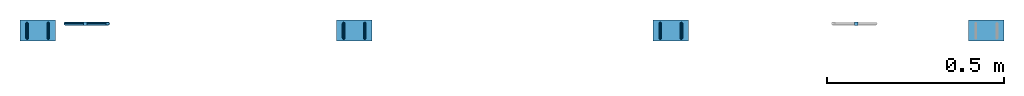
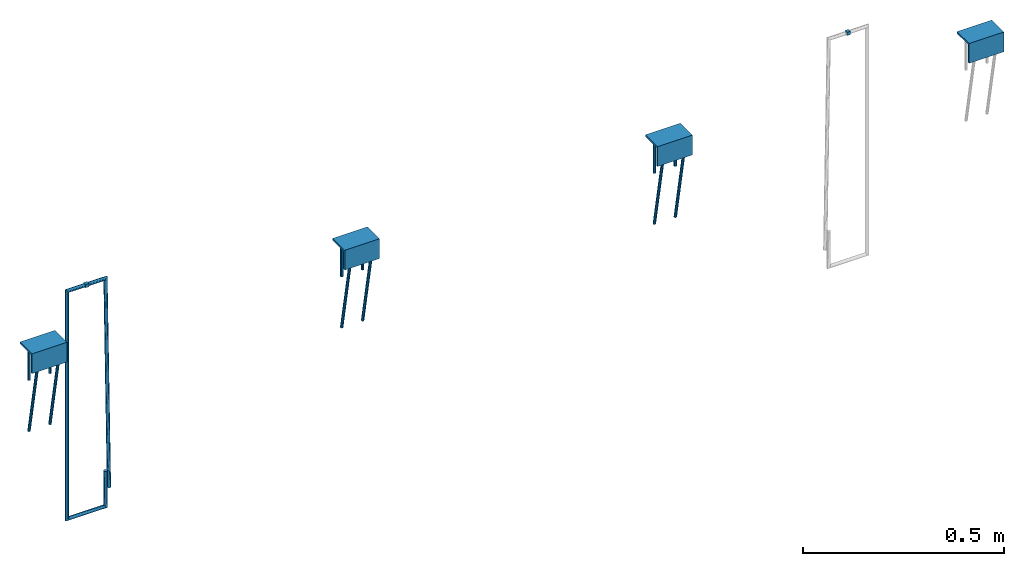
# One storey, part 1 of 2: 7 reinforcing bars, 4 plates, 2 beams, 6 elements without a shape of their own.
"""IFC2X3 building model written with IfcOpenShell, lengths in millimetres."""

from ifc_helpers import new_model, entity, si_unit, frame, origin_with_axes, origin_2d_with_axis, place, context, subcontext, project, spatial, polyline, rectangle, outline, extrude, source, transform, mapped, material, type_object, element, aggregate, save


model = new_model("IFC2X3")

# Units and contexts
model_context = context("Model", 3, precision=1e-05, world=origin_with_axes())
body_context = subcontext(model_context, "Body", "Model", "MODEL_VIEW")
ifc_project = project(units=[si_unit("LENGTHUNIT", "METRE", prefix="MILLI"), si_unit("AREAUNIT", "SQUARE_METRE"), si_unit("VOLUMEUNIT", "CUBIC_METRE"), si_unit("MASSUNIT", "GRAM", prefix="KILO"), si_unit("TIMEUNIT", "SECOND"), si_unit("PLANEANGLEUNIT", "RADIAN"), si_unit("SOLIDANGLEUNIT", "STERADIAN"), si_unit("THERMODYNAMICTEMPERATUREUNIT", "DEGREE_CELSIUS"), si_unit("LUMINOUSINTENSITYUNIT", "LUMEN")], contexts=[model_context])

# Site, building, storey
site_placement = place(None, origin_with_axes())
site = spatial("IfcSite", under=ifc_project, at=site_placement, CompositionType="ELEMENT")
building_placement = place(site_placement, origin_with_axes())
building = spatial("IfcBuilding", under=site, at=building_placement, Name="Undefined", CompositionType="ELEMENT")
storey_placement = place(building_placement, origin_with_axes())
storey = spatial("IfcBuildingStorey", under=building, at=storey_placement, Name="Undefined", CompositionType="ELEMENT", Elevation=0.0)

# Assembly, beam
assembly_1_placement = place(storey_placement, origin_with_axes())
assembly_1 = element("IfcElementAssembly", 1, at=assembly_1_placement, inside=storey, Name="Steel Assembly", AssemblyPlace="NOTDEFINED", PredefinedType="RIGID_FRAME")
ifc_material_1 = material(Name="STEEL/Steel_Undefined")
beam_type = type_object("IfcBeamType", Name="10X10", PredefinedType="NOTDEFINED")
beam_1_placement = place(assembly_1_placement, frame((38911.3076741018, 12049.7402865055, 1630.62234437501), z_axis=(0.0, 0.0, 1.0), x_axis=(1.0, 0.0, 0.0)))
beam_1 = element("IfcBeam", 2, at=beam_1_placement, type_object=beam_type, material=ifc_material_1, Name="10", ObjectType="10X10", context=body_context, shape_type="SweptSolid", body=[
    extrude(rectangle(XDim=10.0, YDim=10.0, at=origin_2d_with_axis()), frame((10.0, 0.0, 0.0), z_axis=(-0.999999999999873, 5.04999964807549e-07, 0.0), x_axis=(-2.17238216866451e-12, -1.0, -1.93119301693619e-12)), (0.0, 0.0, 1.0), 10.0),
])
aggregate(assembly_1, [beam_1])

assembly_2_placement = place(storey_placement, origin_with_axes())
assembly_2 = element("IfcElementAssembly", 3, at=assembly_2_placement, inside=storey, Name="Steel Assembly", AssemblyPlace="NOTDEFINED", PredefinedType="RIGID_FRAME")
beam_2_placement = place(assembly_2_placement, frame((36739.0479725297, 12049.7402865055, 1630.64995363408), z_axis=(0.0, 0.0, 1.0), x_axis=(-0.999999999999873, 5.04999964807549e-07, 0.0)))
beam_2 = element("IfcBeam", 4, at=beam_2_placement, type_object=beam_type, material=ifc_material_1, Name="10", ObjectType="10X10", context=body_context, shape_type="SweptSolid", body=[
    extrude(rectangle(XDim=10.0, YDim=10.0, at=origin_2d_with_axis()), frame((10.0, 0.0, 0.0), z_axis=(-0.999999999999873, 5.04999964807549e-07, 0.0), x_axis=(-2.17238216866451e-12, -1.0, -1.93119301693619e-12)), (0.0, 0.0, 1.0), 10.0),
])

# Assembly, plate
assembly_3_placement = place(storey_placement, origin_with_axes())
assembly_3 = element("IfcElementAssembly", 5, at=assembly_3_placement, inside=storey, Name="Steel Assembly", AssemblyPlace="NOTDEFINED", PredefinedType="RIGID_FRAME")
plate_type = type_object("IfcPlateType", Name="PL100X60", PredefinedType="NOTDEFINED")
plate_1_placement = place(assembly_3_placement, frame((39284.9367436631, 11999.9982796697, 1515.55037109356), z_axis=(-0.999999999999873, 5.04999964807549e-07, 0.0), x_axis=(0.0, 1.0, 0.0)))
plate_1 = element("IfcPlate", 6, at=plate_1_placement, type_object=plate_type, material=ifc_material_1, ObjectType="PL100X60", context=body_context, shape_type="SweptSolid", body=[
    extrude(outline(polyline([(0.0, 0.0), (60.0000000000491, 0.0), (60.0000000000491, 6.0), (6.00000000000546, 6.0), (6.00000000000546, 60.0), (2.5465851649642e-11, 60.0), (0.0, 0.0)])), frame((1.81898940354586e-12, -4.54747350886464e-13, -50.0), z_axis=(0.0, 0.0, 1.0), x_axis=(1.0, 0.0, 0.0)), (0.0, 0.0, 1.0), 100.0),
])
aggregate(assembly_3, [plate_1])

assembly_4_placement = place(storey_placement, origin_with_axes())
assembly_4 = element("IfcElementAssembly", 7, at=assembly_4_placement, inside=storey, Name="Steel Assembly", AssemblyPlace="NOTDEFINED", PredefinedType="RIGID_FRAME")
plate_2_placement = place(assembly_4_placement, frame((38391.9567435577, 11999.9987281135, 1515.55037109323), z_axis=(-0.999999999999873, 5.04999964807549e-07, 0.0), x_axis=(0.0, 1.0, 0.0)))
plate_2 = element("IfcPlate", 8, at=plate_2_placement, type_object=plate_type, material=ifc_material_1, ObjectType="PL100X60", context=body_context, shape_type="SweptSolid", body=[
    extrude(outline(polyline([(0.0, 0.0), (60.0000000000491, 0.0), (60.0000000000491, 6.0), (6.00000000000546, 6.0), (6.00000000000546, 60.0), (2.5465851649642e-11, 60.0), (0.0, 0.0)])), frame((1.81898940354586e-12, -4.54747350886464e-13, -50.0), z_axis=(0.0, 0.0, 1.0), x_axis=(1.0, 0.0, 0.0)), (0.0, 0.0, 1.0), 100.0),
])

assembly_5_placement = place(storey_placement, origin_with_axes())
assembly_5 = element("IfcElementAssembly", 9, at=assembly_5_placement, inside=storey, Name="Steel Assembly", AssemblyPlace="NOTDEFINED", PredefinedType="RIGID_FRAME")
plate_3_placement = place(assembly_5_placement, frame((37495.9767435481, 11999.999180887, 1515.55037109289), z_axis=(-0.999999999999873, 5.04999964807549e-07, 0.0), x_axis=(0.0, 1.0, 0.0)))
plate_3 = element("IfcPlate", 10, at=plate_3_placement, type_object=plate_type, material=ifc_material_1, ObjectType="PL100X60", context=body_context, shape_type="SweptSolid", body=[
    extrude(outline(polyline([(0.0, 0.0), (60.0000000000491, 0.0), (60.0000000000491, 6.0), (6.00000000000546, 6.0), (6.00000000000546, 60.0), (2.5465851649642e-11, 60.0), (0.0, 0.0)])), frame((1.81898940354586e-12, -4.54747350886464e-13, -50.0), z_axis=(0.0, 0.0, 1.0), x_axis=(1.0, 0.0, 0.0)), (0.0, 0.0, 1.0), 100.0),
])

assembly_6_placement = place(storey_placement, origin_with_axes())
assembly_6 = element("IfcElementAssembly", 11, at=assembly_6_placement, inside=storey, Name="Steel Assembly", AssemblyPlace="NOTDEFINED", PredefinedType="RIGID_FRAME")
plate_4_placement = place(assembly_6_placement, frame((36599.996743559, 11999.9996336118, 1515.55037109256), z_axis=(-0.999999999999873, 5.04999964807549e-07, 0.0), x_axis=(0.0, 1.0, 0.0)))
plate_4 = element("IfcPlate", 12, at=plate_4_placement, type_object=plate_type, material=ifc_material_1, ObjectType="PL100X60", context=body_context, shape_type="SweptSolid", body=[
    extrude(outline(polyline([(0.0, 0.0), (60.0000000000491, 0.0), (60.0000000000491, 6.0), (6.00000000000546, 6.0), (6.00000000000546, 60.0), (2.5465851649642e-11, 60.0), (0.0, 0.0)])), frame((1.81898940354586e-12, -4.54747350886464e-13, -50.0), z_axis=(0.0, 0.0, 1.0), x_axis=(1.0, 0.0, 0.0)), (0.0, 0.0, 1.0), 100.0),
])

# Reinforcing bar
ifc_material_2 = material(Name="Undefined")
ifc_direction_1 = entity("IfcDirection", [-0.98195706540053, 1.76798970064306e-12, 0.189103997075631])
ifc_direction_2 = entity("IfcDirection", [-2.17238216866451e-12, -1.0, -1.93119301693619e-12])
ifc_direction_3 = entity("IfcDirection", [-0.18910399414149, 2.3071547736201e-12, -0.981957065965582])
shared_shape_1 = source(origin_with_axes(), body_context, "Body", "AdvancedSweptSolid", [
    entity("IfcSweptDiskSolid", entity("IfcCompositeCurve", [entity("IfcCompositeCurveSegment", "CONTINUOUS", True, entity("IfcTrimmedCurve", entity("IfcLine", entity("IfcCartesianPoint", [0.0, 0.0, 0.0]), entity("IfcVector", ifc_direction_1, 1.0)), [entity("IfcParameterValue", 0.0)], [entity("IfcParameterValue", 90.9999999521698)], True, "PARAMETER")), entity("IfcCompositeCurveSegment", "CONTINUOUS", True, entity("IfcTrimmedCurve", entity("IfcCircle", entity("IfcAxis2Placement3D", entity("IfcCartesianPoint", [-92.3837568576909, 1.97801539136402e-10, 1.49715067842899]), ifc_direction_2, entity("IfcDirection", [0.189103997075631, -2.30715477890295e-12, 0.98195706540053])), 16.0), [entity("IfcParameterValue", 0.0)], [entity("IfcParameterValue", 1.57079632978295)], True, "PARAMETER")), entity("IfcCompositeCurveSegment", "CONTINUOUS", True, entity("IfcTrimmedCurve", entity("IfcLine", entity("IfcCartesianPoint", [-108.09506991314, 2.26089374456993e-10, 4.52281458469285]), entity("IfcVector", ifc_direction_3, 1.0)), [entity("IfcParameterValue", 0.0)], [entity("IfcParameterValue", 8.99744408063349)], True, "PARAMETER")), entity("IfcCompositeCurveSegment", "CONTINUOUS", True, entity("IfcTrimmedCurve", entity("IfcCircle", entity("IfcAxis2Placement3D", entity("IfcCartesianPoint", [-94.0852094704034, 2.18367057009855e-10, -7.33795311217925]), ifc_direction_2, ifc_direction_1), 16.0), [entity("IfcParameterValue", 0.0)], [entity("IfcParameterValue", 1.57079632834512)], True, "PARAMETER")), entity("IfcCompositeCurveSegment", "CONTINUOUS", True, entity("IfcTrimmedCurve", entity("IfcLine", entity("IfcCartesianPoint", [-97.1108733523112, 2.55281533343625e-10, -23.049266172319]), entity("IfcVector", entity("IfcDirection", [0.981957066258735, -1.78005084783605e-12, -0.189103992619242]), 1.0)), [entity("IfcParameterValue", 0.0)], [entity("IfcParameterValue", 31.5166760442662)], True, "PARAMETER")), entity("IfcCompositeCurveSegment", "CONTINUOUS", True, entity("IfcTrimmedCurve", entity("IfcCircle", entity("IfcAxis2Placement3D", entity("IfcCartesianPoint", [-63.1371867237488, 1.64690684076105e-10, -13.2978823862372]), ifc_direction_2, ifc_direction_3), 16.0), [entity("IfcParameterValue", 0.0)], [entity("IfcParameterValue", 0.191081767948963)], True, "PARAMETER")), entity("IfcCompositeCurveSegment", "DISCONTINUOUS", True, entity("IfcTrimmedCurve", entity("IfcLine", entity("IfcCartesianPoint", [-63.1238719610507, 1.93143408258578e-10, -29.2978768461454]), entity("IfcVector", entity("IfcDirection", [0.999999653744265, -2.15704623730578e-12, 0.000832172668634111]), 1.0)), [entity("IfcParameterValue", 0.0)], [entity("IfcParameterValue", 214.345817899972)], True, "PARAMETER"))], False), 4.0, None, 0.0, 349.192612403118),
])
reinforcing_bar_1_placement = place(assembly_4_placement, frame((38421.9567481027, 12008.9987121001, 1458.45037261911), z_axis=(4.9600000056671e-07, 0.981957081013335, 0.189103916002616), x_axis=(9.50000027587495e-08, 0.189103916002592, -0.98195708101346)))
reinforcing_bar_1 = element("IfcReinforcingBar", 13, at=reinforcing_bar_1_placement, material=ifc_material_2, Name="EB_REBAR", BarRole="NOTDEFINED", CrossSectionArea=0.0, NominalDiameter=8.0, context=body_context, shape_type="MappedRepresentation", body=[
    mapped(shared_shape_1, transform((65.5900530622035, -1.96450855582952e-10, 29.119504115306))),
])

ifc_direction_4 = entity("IfcDirection", [-0.98195706540053, 1.76798970064306e-12, 0.189103997075631])
ifc_direction_5 = entity("IfcDirection", [-2.17238216866451e-12, -1.0, -1.93119301693619e-12])
ifc_direction_6 = entity("IfcDirection", [-0.18910399414149, 2.3071547736201e-12, -0.981957065965582])
shared_shape_2 = source(origin_with_axes(), body_context, "Body", "AdvancedSweptSolid", [
    entity("IfcSweptDiskSolid", entity("IfcCompositeCurve", [entity("IfcCompositeCurveSegment", "CONTINUOUS", True, entity("IfcTrimmedCurve", entity("IfcLine", entity("IfcCartesianPoint", [0.0, 0.0, 0.0]), entity("IfcVector", ifc_direction_4, 1.0)), [entity("IfcParameterValue", 0.0)], [entity("IfcParameterValue", 90.9999999521698)], True, "PARAMETER")), entity("IfcCompositeCurveSegment", "CONTINUOUS", True, entity("IfcTrimmedCurve", entity("IfcCircle", entity("IfcAxis2Placement3D", entity("IfcCartesianPoint", [-92.3837568576909, 1.97801539136402e-10, 1.49715067842899]), ifc_direction_5, entity("IfcDirection", [0.189103997075631, -2.30715477890295e-12, 0.98195706540053])), 16.0), [entity("IfcParameterValue", 0.0)], [entity("IfcParameterValue", 1.57079632978295)], True, "PARAMETER")), entity("IfcCompositeCurveSegment", "CONTINUOUS", True, entity("IfcTrimmedCurve", entity("IfcLine", entity("IfcCartesianPoint", [-108.09506991314, 2.26089374456993e-10, 4.52281458469285]), entity("IfcVector", ifc_direction_6, 1.0)), [entity("IfcParameterValue", 0.0)], [entity("IfcParameterValue", 8.9974440806329)], True, "PARAMETER")), entity("IfcCompositeCurveSegment", "CONTINUOUS", True, entity("IfcTrimmedCurve", entity("IfcCircle", entity("IfcAxis2Placement3D", entity("IfcCartesianPoint", [-94.0852094704034, 2.18367057009855e-10, -7.33795311217925]), ifc_direction_5, ifc_direction_4), 16.0), [entity("IfcParameterValue", 0.0)], [entity("IfcParameterValue", 1.57079632834515)], True, "PARAMETER")), entity("IfcCompositeCurveSegment", "CONTINUOUS", True, entity("IfcTrimmedCurve", entity("IfcLine", entity("IfcCartesianPoint", [-97.1108733523112, 2.55281533343625e-10, -23.049266172319]), entity("IfcVector", entity("IfcDirection", [0.981957066258735, -1.78005084783605e-12, -0.189103992619242]), 1.0)), [entity("IfcParameterValue", 0.0)], [entity("IfcParameterValue", 31.5166760442657)], True, "PARAMETER")), entity("IfcCompositeCurveSegment", "CONTINUOUS", True, entity("IfcTrimmedCurve", entity("IfcCircle", entity("IfcAxis2Placement3D", entity("IfcCartesianPoint", [-63.1371867237488, 1.64690684076105e-10, -13.2978823862372]), ifc_direction_5, ifc_direction_6), 16.0), [entity("IfcParameterValue", 0.0)], [entity("IfcParameterValue", 0.191081767948925)], True, "PARAMETER")), entity("IfcCompositeCurveSegment", "DISCONTINUOUS", True, entity("IfcTrimmedCurve", entity("IfcLine", entity("IfcCartesianPoint", [-63.1238719610507, 1.93143408258578e-10, -29.2978768461454]), entity("IfcVector", entity("IfcDirection", [0.999999653744265, -2.15704623730578e-12, 0.000832172668634111]), 1.0)), [entity("IfcParameterValue", 0.0)], [entity("IfcParameterValue", 214.345817899972)], True, "PARAMETER"))], False), 4.0, None, 0.0, 349.192612403118),
])
reinforcing_bar_2_placement = place(assembly_4_placement, frame((38361.9567481027, 12008.9987424001, 1458.45037261911), z_axis=(4.9600000056671e-07, 0.981957081013335, 0.189103916002616), x_axis=(9.50000027587495e-08, 0.189103916002592, -0.98195708101346)))
reinforcing_bar_2 = element("IfcReinforcingBar", 14, at=reinforcing_bar_2_placement, material=ifc_material_2, Name="EB_REBAR", BarRole="NOTDEFINED", CrossSectionArea=0.0, NominalDiameter=8.0, context=body_context, shape_type="MappedRepresentation", body=[
    mapped(shared_shape_2, transform((65.5900530622035, -1.96450855582952e-10, 29.119504115306))),
])

aggregate(assembly_4, [plate_2, reinforcing_bar_1, reinforcing_bar_2])

ifc_direction_7 = entity("IfcDirection", [-0.98195706540053, 1.76798970064306e-12, 0.189103997075631])
ifc_direction_8 = entity("IfcDirection", [-2.17238216866451e-12, -1.0, -1.93119301693619e-12])
ifc_direction_9 = entity("IfcDirection", [-0.18910399414149, 2.3071547736201e-12, -0.981957065965582])
shared_shape_3 = source(origin_with_axes(), body_context, "Body", "AdvancedSweptSolid", [
    entity("IfcSweptDiskSolid", entity("IfcCompositeCurve", [entity("IfcCompositeCurveSegment", "CONTINUOUS", True, entity("IfcTrimmedCurve", entity("IfcLine", entity("IfcCartesianPoint", [0.0, 0.0, 0.0]), entity("IfcVector", ifc_direction_7, 1.0)), [entity("IfcParameterValue", 0.0)], [entity("IfcParameterValue", 90.9999999521693)], True, "PARAMETER")), entity("IfcCompositeCurveSegment", "CONTINUOUS", True, entity("IfcTrimmedCurve", entity("IfcCircle", entity("IfcAxis2Placement3D", entity("IfcCartesianPoint", [-92.3837568576909, 1.97801539136402e-10, 1.49715067842899]), ifc_direction_8, entity("IfcDirection", [0.189103997075631, -2.30715477890295e-12, 0.98195706540053])), 16.0), [entity("IfcParameterValue", 0.0)], [entity("IfcParameterValue", 1.57079632978294)], True, "PARAMETER")), entity("IfcCompositeCurveSegment", "CONTINUOUS", True, entity("IfcTrimmedCurve", entity("IfcLine", entity("IfcCartesianPoint", [-108.09506991314, 2.26089374456993e-10, 4.52281458469285]), entity("IfcVector", ifc_direction_9, 1.0)), [entity("IfcParameterValue", 0.0)], [entity("IfcParameterValue", 8.99744408063045)], True, "PARAMETER")), entity("IfcCompositeCurveSegment", "CONTINUOUS", True, entity("IfcTrimmedCurve", entity("IfcCircle", entity("IfcAxis2Placement3D", entity("IfcCartesianPoint", [-94.0852094704034, 2.18367057009855e-10, -7.33795311217925]), ifc_direction_8, ifc_direction_7), 16.0), [entity("IfcParameterValue", 0.0)], [entity("IfcParameterValue", 1.57079632834509)], True, "PARAMETER")), entity("IfcCompositeCurveSegment", "CONTINUOUS", True, entity("IfcTrimmedCurve", entity("IfcLine", entity("IfcCartesianPoint", [-97.1108733523112, 2.55281533343625e-10, -23.049266172319]), entity("IfcVector", entity("IfcDirection", [0.981957066258735, -1.78005084783605e-12, -0.189103992619242]), 1.0)), [entity("IfcParameterValue", 0.0)], [entity("IfcParameterValue", 31.5166760442663)], True, "PARAMETER")), entity("IfcCompositeCurveSegment", "CONTINUOUS", True, entity("IfcTrimmedCurve", entity("IfcCircle", entity("IfcAxis2Placement3D", entity("IfcCartesianPoint", [-63.1371867237488, 1.64690684076105e-10, -13.2978823862372]), ifc_direction_8, ifc_direction_9), 16.0), [entity("IfcParameterValue", 0.0)], [entity("IfcParameterValue", 0.19108176794901)], True, "PARAMETER")), entity("IfcCompositeCurveSegment", "DISCONTINUOUS", True, entity("IfcTrimmedCurve", entity("IfcLine", entity("IfcCartesianPoint", [-63.1238719610507, 1.93143408258578e-10, -29.2978768461454]), entity("IfcVector", entity("IfcDirection", [0.999999653744265, -2.15704623730578e-12, 0.000832172668634111]), 1.0)), [entity("IfcParameterValue", 0.0)], [entity("IfcParameterValue", 214.345817899971)], True, "PARAMETER"))], False), 4.0, None, 0.0, 349.192612403114),
])
reinforcing_bar_3_placement = place(assembly_5_placement, frame((37525.9767480931, 12008.9991648736, 1458.45037261877), z_axis=(4.9600000056671e-07, 0.981957081013335, 0.189103916002616), x_axis=(9.50000027587495e-08, 0.189103916002592, -0.98195708101346)))
reinforcing_bar_3 = element("IfcReinforcingBar", 15, at=reinforcing_bar_3_placement, material=ifc_material_2, Name="EB_REBAR", BarRole="NOTDEFINED", CrossSectionArea=0.0, NominalDiameter=8.0, context=body_context, shape_type="MappedRepresentation", body=[
    mapped(shared_shape_3, transform((65.5900530622035, -1.96450855582952e-10, 29.119504115306))),
])

ifc_direction_10 = entity("IfcDirection", [-0.98195706540053, 1.76798970064306e-12, 0.189103997075631])
ifc_direction_11 = entity("IfcDirection", [-2.17238216866451e-12, -1.0, -1.93119301693619e-12])
ifc_direction_12 = entity("IfcDirection", [-0.18910399414149, 2.3071547736201e-12, -0.981957065965582])
shared_shape_4 = source(origin_with_axes(), body_context, "Body", "AdvancedSweptSolid", [
    entity("IfcSweptDiskSolid", entity("IfcCompositeCurve", [entity("IfcCompositeCurveSegment", "CONTINUOUS", True, entity("IfcTrimmedCurve", entity("IfcLine", entity("IfcCartesianPoint", [0.0, 0.0, 0.0]), entity("IfcVector", ifc_direction_10, 1.0)), [entity("IfcParameterValue", 0.0)], [entity("IfcParameterValue", 90.9999999521691)], True, "PARAMETER")), entity("IfcCompositeCurveSegment", "CONTINUOUS", True, entity("IfcTrimmedCurve", entity("IfcCircle", entity("IfcAxis2Placement3D", entity("IfcCartesianPoint", [-92.3837568576909, 1.97801539136402e-10, 1.49715067842899]), ifc_direction_11, entity("IfcDirection", [0.189103997075631, -2.30715477890295e-12, 0.98195706540053])), 16.0), [entity("IfcParameterValue", 0.0)], [entity("IfcParameterValue", 1.57079632978295)], True, "PARAMETER")), entity("IfcCompositeCurveSegment", "CONTINUOUS", True, entity("IfcTrimmedCurve", entity("IfcLine", entity("IfcCartesianPoint", [-108.09506991314, 2.26089374456993e-10, 4.52281458469285]), entity("IfcVector", ifc_direction_12, 1.0)), [entity("IfcParameterValue", 0.0)], [entity("IfcParameterValue", 8.99744408063162)], True, "PARAMETER")), entity("IfcCompositeCurveSegment", "CONTINUOUS", True, entity("IfcTrimmedCurve", entity("IfcCircle", entity("IfcAxis2Placement3D", entity("IfcCartesianPoint", [-94.0852094704034, 2.18367057009855e-10, -7.33795311217925]), ifc_direction_11, ifc_direction_10), 16.0), [entity("IfcParameterValue", 0.0)], [entity("IfcParameterValue", 1.57079632834511)], True, "PARAMETER")), entity("IfcCompositeCurveSegment", "CONTINUOUS", True, entity("IfcTrimmedCurve", entity("IfcLine", entity("IfcCartesianPoint", [-97.1108733523112, 2.55281533343625e-10, -23.049266172319]), entity("IfcVector", entity("IfcDirection", [0.981957066258735, -1.78005084783605e-12, -0.189103992619242]), 1.0)), [entity("IfcParameterValue", 0.0)], [entity("IfcParameterValue", 31.5166760442658)], True, "PARAMETER")), entity("IfcCompositeCurveSegment", "CONTINUOUS", True, entity("IfcTrimmedCurve", entity("IfcCircle", entity("IfcAxis2Placement3D", entity("IfcCartesianPoint", [-63.1371867237488, 1.64690684076105e-10, -13.2978823862372]), ifc_direction_11, ifc_direction_12), 16.0), [entity("IfcParameterValue", 0.0)], [entity("IfcParameterValue", 0.191081767948956)], True, "PARAMETER")), entity("IfcCompositeCurveSegment", "DISCONTINUOUS", True, entity("IfcTrimmedCurve", entity("IfcLine", entity("IfcCartesianPoint", [-63.1238719610507, 1.93143408258578e-10, -29.2978768461454]), entity("IfcVector", entity("IfcDirection", [0.999999653744265, -2.15704623730578e-12, 0.000832172668634111]), 1.0)), [entity("IfcParameterValue", 0.0)], [entity("IfcParameterValue", 214.345817899972)], True, "PARAMETER"))], False), 4.0, None, 0.0, 349.192612403115),
])
reinforcing_bar_4_placement = place(assembly_5_placement, frame((37465.9767480931, 12008.9991951736, 1458.45037261877), z_axis=(4.9600000056671e-07, 0.981957081013335, 0.189103916002616), x_axis=(9.50000027587495e-08, 0.189103916002592, -0.98195708101346)))
reinforcing_bar_4 = element("IfcReinforcingBar", 16, at=reinforcing_bar_4_placement, material=ifc_material_2, Name="EB_REBAR", BarRole="NOTDEFINED", CrossSectionArea=0.0, NominalDiameter=8.0, context=body_context, shape_type="MappedRepresentation", body=[
    mapped(shared_shape_4, transform((65.5900530622035, -1.96450855582952e-10, 29.119504115306))),
])

aggregate(assembly_5, [plate_3, reinforcing_bar_3, reinforcing_bar_4])

ifc_direction_13 = entity("IfcDirection", [-0.98195706540053, 1.76798970064306e-12, 0.189103997075631])
ifc_direction_14 = entity("IfcDirection", [-2.17238216866451e-12, -1.0, -1.93119301693619e-12])
ifc_direction_15 = entity("IfcDirection", [-0.18910399414149, 2.3071547736201e-12, -0.981957065965582])
shared_shape_5 = source(origin_with_axes(), body_context, "Body", "AdvancedSweptSolid", [
    entity("IfcSweptDiskSolid", entity("IfcCompositeCurve", [entity("IfcCompositeCurveSegment", "CONTINUOUS", True, entity("IfcTrimmedCurve", entity("IfcLine", entity("IfcCartesianPoint", [0.0, 0.0, 0.0]), entity("IfcVector", ifc_direction_13, 1.0)), [entity("IfcParameterValue", 0.0)], [entity("IfcParameterValue", 90.9999999521694)], True, "PARAMETER")), entity("IfcCompositeCurveSegment", "CONTINUOUS", True, entity("IfcTrimmedCurve", entity("IfcCircle", entity("IfcAxis2Placement3D", entity("IfcCartesianPoint", [-92.3837568576909, 1.97801539136402e-10, 1.49715067842899]), ifc_direction_14, entity("IfcDirection", [0.189103997075631, -2.30715477890295e-12, 0.98195706540053])), 16.0), [entity("IfcParameterValue", 0.0)], [entity("IfcParameterValue", 1.57079632978296)], True, "PARAMETER")), entity("IfcCompositeCurveSegment", "CONTINUOUS", True, entity("IfcTrimmedCurve", entity("IfcLine", entity("IfcCartesianPoint", [-108.09506991314, 2.26089374456993e-10, 4.52281458469285]), entity("IfcVector", ifc_direction_15, 1.0)), [entity("IfcParameterValue", 0.0)], [entity("IfcParameterValue", 8.99744408063281)], True, "PARAMETER")), entity("IfcCompositeCurveSegment", "CONTINUOUS", True, entity("IfcTrimmedCurve", entity("IfcCircle", entity("IfcAxis2Placement3D", entity("IfcCartesianPoint", [-94.0852094704034, 2.18367057009855e-10, -7.33795311217925]), ifc_direction_14, ifc_direction_13), 16.0), [entity("IfcParameterValue", 0.0)], [entity("IfcParameterValue", 1.57079632834514)], True, "PARAMETER")), entity("IfcCompositeCurveSegment", "CONTINUOUS", True, entity("IfcTrimmedCurve", entity("IfcLine", entity("IfcCartesianPoint", [-97.1108733523112, 2.55281533343625e-10, -23.049266172319]), entity("IfcVector", entity("IfcDirection", [0.981957066258735, -1.78005084783605e-12, -0.189103992619242]), 1.0)), [entity("IfcParameterValue", 0.0)], [entity("IfcParameterValue", 31.5166760442657)], True, "PARAMETER")), entity("IfcCompositeCurveSegment", "CONTINUOUS", True, entity("IfcTrimmedCurve", entity("IfcCircle", entity("IfcAxis2Placement3D", entity("IfcCartesianPoint", [-63.1371867237488, 1.64690684076105e-10, -13.2978823862372]), ifc_direction_14, ifc_direction_15), 16.0), [entity("IfcParameterValue", 0.0)], [entity("IfcParameterValue", 0.191081767948927)], True, "PARAMETER")), entity("IfcCompositeCurveSegment", "DISCONTINUOUS", True, entity("IfcTrimmedCurve", entity("IfcLine", entity("IfcCartesianPoint", [-63.1238719610507, 1.93143408258578e-10, -29.2978768461454]), entity("IfcVector", entity("IfcDirection", [0.999999653744265, -2.15704623730578e-12, 0.000832172668634111]), 1.0)), [entity("IfcParameterValue", 0.0)], [entity("IfcParameterValue", 214.345817899972)], True, "PARAMETER"))], False), 4.0, None, 0.0, 349.192612403117),
])
reinforcing_bar_5_placement = place(assembly_6_placement, frame((36629.996748104, 12008.9996175983, 1458.45037261844), z_axis=(4.9600000056671e-07, 0.981957081013335, 0.189103916002616), x_axis=(9.50000027587495e-08, 0.189103916002592, -0.98195708101346)))
reinforcing_bar_5 = element("IfcReinforcingBar", 17, at=reinforcing_bar_5_placement, material=ifc_material_2, Name="EB_REBAR", BarRole="NOTDEFINED", CrossSectionArea=0.0, NominalDiameter=8.0, context=body_context, shape_type="MappedRepresentation", body=[
    mapped(shared_shape_5, transform((65.5900530622035, -1.96450855582952e-10, 29.119504115306))),
])

ifc_direction_16 = entity("IfcDirection", [-0.98195706540053, 1.76798970064306e-12, 0.189103997075631])
ifc_direction_17 = entity("IfcDirection", [-2.17238216866451e-12, -1.0, -1.93119301693619e-12])
ifc_direction_18 = entity("IfcDirection", [-0.18910399414149, 2.3071547736201e-12, -0.981957065965582])
shared_shape_6 = source(origin_with_axes(), body_context, "Body", "AdvancedSweptSolid", [
    entity("IfcSweptDiskSolid", entity("IfcCompositeCurve", [entity("IfcCompositeCurveSegment", "CONTINUOUS", True, entity("IfcTrimmedCurve", entity("IfcLine", entity("IfcCartesianPoint", [0.0, 0.0, 0.0]), entity("IfcVector", ifc_direction_16, 1.0)), [entity("IfcParameterValue", 0.0)], [entity("IfcParameterValue", 90.9999999521696)], True, "PARAMETER")), entity("IfcCompositeCurveSegment", "CONTINUOUS", True, entity("IfcTrimmedCurve", entity("IfcCircle", entity("IfcAxis2Placement3D", entity("IfcCartesianPoint", [-92.3837568576909, 1.97801539136402e-10, 1.49715067842899]), ifc_direction_17, entity("IfcDirection", [0.189103997075631, -2.30715477890295e-12, 0.98195706540053])), 16.0), [entity("IfcParameterValue", 0.0)], [entity("IfcParameterValue", 1.57079632978296)], True, "PARAMETER")), entity("IfcCompositeCurveSegment", "CONTINUOUS", True, entity("IfcTrimmedCurve", entity("IfcLine", entity("IfcCartesianPoint", [-108.09506991314, 2.26089374456993e-10, 4.52281458469285]), entity("IfcVector", ifc_direction_18, 1.0)), [entity("IfcParameterValue", 0.0)], [entity("IfcParameterValue", 8.99744408063338)], True, "PARAMETER")), entity("IfcCompositeCurveSegment", "CONTINUOUS", True, entity("IfcTrimmedCurve", entity("IfcCircle", entity("IfcAxis2Placement3D", entity("IfcCartesianPoint", [-94.0852094704034, 2.18367057009855e-10, -7.33795311217925]), ifc_direction_17, ifc_direction_16), 16.0), [entity("IfcParameterValue", 0.0)], [entity("IfcParameterValue", 1.57079632834511)], True, "PARAMETER")), entity("IfcCompositeCurveSegment", "CONTINUOUS", True, entity("IfcTrimmedCurve", entity("IfcLine", entity("IfcCartesianPoint", [-97.1108733523112, 2.55281533343625e-10, -23.049266172319]), entity("IfcVector", entity("IfcDirection", [0.981957066258735, -1.78005084783605e-12, -0.189103992619242]), 1.0)), [entity("IfcParameterValue", 0.0)], [entity("IfcParameterValue", 31.5166760442665)], True, "PARAMETER")), entity("IfcCompositeCurveSegment", "CONTINUOUS", True, entity("IfcTrimmedCurve", entity("IfcCircle", entity("IfcAxis2Placement3D", entity("IfcCartesianPoint", [-63.1371867237488, 1.64690684076105e-10, -13.2978823862372]), ifc_direction_17, ifc_direction_18), 16.0), [entity("IfcParameterValue", 0.0)], [entity("IfcParameterValue", 0.191081767948962)], True, "PARAMETER")), entity("IfcCompositeCurveSegment", "DISCONTINUOUS", True, entity("IfcTrimmedCurve", entity("IfcLine", entity("IfcCartesianPoint", [-63.1238719610507, 1.93143408258578e-10, -29.2978768461454]), entity("IfcVector", entity("IfcDirection", [0.999999653744265, -2.15704623730578e-12, 0.000832172668634111]), 1.0)), [entity("IfcParameterValue", 0.0)], [entity("IfcParameterValue", 214.345817899972)], True, "PARAMETER"))], False), 4.0, None, 0.0, 349.192612403118),
])
reinforcing_bar_6_placement = place(assembly_6_placement, frame((36569.996748104, 12008.9996478983, 1458.45037261844), z_axis=(4.9600000056671e-07, 0.981957081013335, 0.189103916002616), x_axis=(9.50000027587495e-08, 0.189103916002592, -0.98195708101346)))
reinforcing_bar_6 = element("IfcReinforcingBar", 18, at=reinforcing_bar_6_placement, material=ifc_material_2, Name="EB_REBAR", BarRole="NOTDEFINED", CrossSectionArea=0.0, NominalDiameter=8.0, context=body_context, shape_type="MappedRepresentation", body=[
    mapped(shared_shape_6, transform((65.5900530622035, -1.96450855582952e-10, 29.119504115306))),
])

aggregate(assembly_6, [plate_4, reinforcing_bar_5, reinforcing_bar_6])

ifc_material_3 = material(Name="Undefined_round_bar")
shared_shape_7 = source(origin_with_axes(), body_context, "Body", "AdvancedSweptSolid", [
    entity("IfcSweptDiskSolid", entity("IfcCompositeCurve", [entity("IfcCompositeCurveSegment", "CONTINUOUS", True, entity("IfcTrimmedCurve", entity("IfcLine", entity("IfcCartesianPoint", [0.0, 0.0, 0.0]), entity("IfcVector", entity("IfcDirection", [-0.999999999999873, 5.04999964807549e-07, 0.0]), 1.0)), [entity("IfcParameterValue", 0.0)], [entity("IfcParameterValue", 108.0)], True, "PARAMETER")), entity("IfcCompositeCurveSegment", "CONTINUOUS", True, entity("IfcTrimmedCurve", entity("IfcLine", entity("IfcCartesianPoint", [-108.0, 0.0, 0.0]), entity("IfcVector", entity("IfcDirection", [0.0, 0.0, -1.0]), 1.0)), [entity("IfcParameterValue", 0.0)], [entity("IfcParameterValue", 110.0)], True, "PARAMETER")), entity("IfcCompositeCurveSegment", "CONTINUOUS", True, entity("IfcTrimmedCurve", entity("IfcLine", entity("IfcCartesianPoint", [-108.0, 0.0, -110.0]), entity("IfcVector", entity("IfcDirection", [1.0, 0.0, 0.0]), 1.0)), [entity("IfcParameterValue", 0.0)], [entity("IfcParameterValue", 690.0)], True, "PARAMETER")), entity("IfcCompositeCurveSegment", "CONTINUOUS", True, entity("IfcTrimmedCurve", entity("IfcLine", entity("IfcCartesianPoint", [582.0, 0.0, -110.0]), entity("IfcVector", entity("IfcDirection", [0.0, 0.0, 1.0]), 1.0)), [entity("IfcParameterValue", 0.0)], [entity("IfcParameterValue", 110.0)], True, "PARAMETER")), entity("IfcCompositeCurveSegment", "CONTINUOUS", True, entity("IfcTrimmedCurve", entity("IfcLine", entity("IfcCartesianPoint", [582.0, 0.0, 0.0]), entity("IfcVector", entity("IfcDirection", [-0.999876022811326, 0.0, 0.015746079099391]), 1.0)), [entity("IfcParameterValue", 0.0)], [entity("IfcParameterValue", 635.078735276186)], True, "PARAMETER"))], False), 5.0, None, 0.0, 1653.07873527619),
])
reinforcing_bar_7_placement = place(assembly_2_placement, frame((36679.0479725297, 12049.7402865055, 940.649953634078), z_axis=(1.0, 0.0, 0.0), x_axis=(0.0, 0.0, 1.0)))
reinforcing_bar_7 = element("IfcReinforcingBar", 19, at=reinforcing_bar_7_placement, material=ifc_material_3, Name="10", BarRole="NOTDEFINED", CrossSectionArea=0.0, NominalDiameter=10.0, context=body_context, shape_type="MappedRepresentation", body=[
    mapped(shared_shape_7, transform((108.0, 0.0, 110.0))),
])

aggregate(assembly_2, [beam_2, reinforcing_bar_7])

save(model, "model.ifc")
